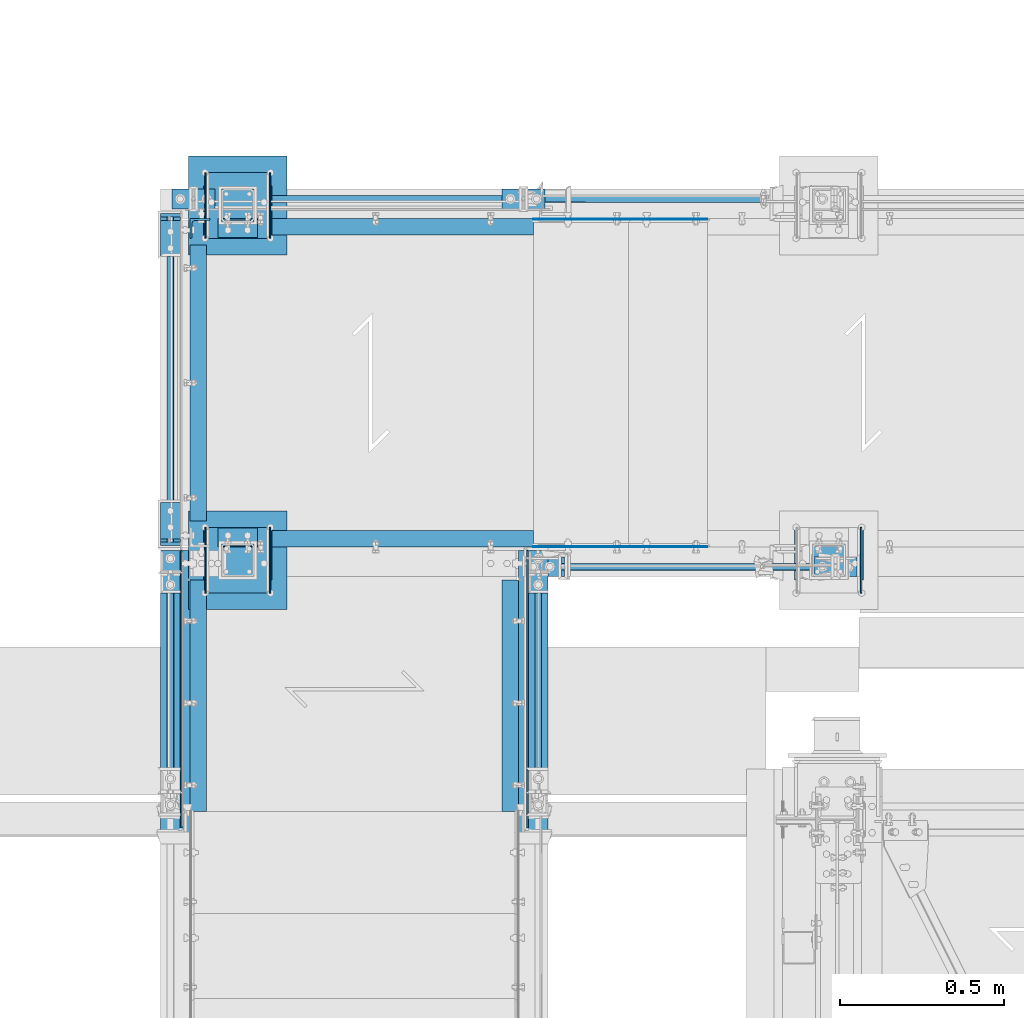
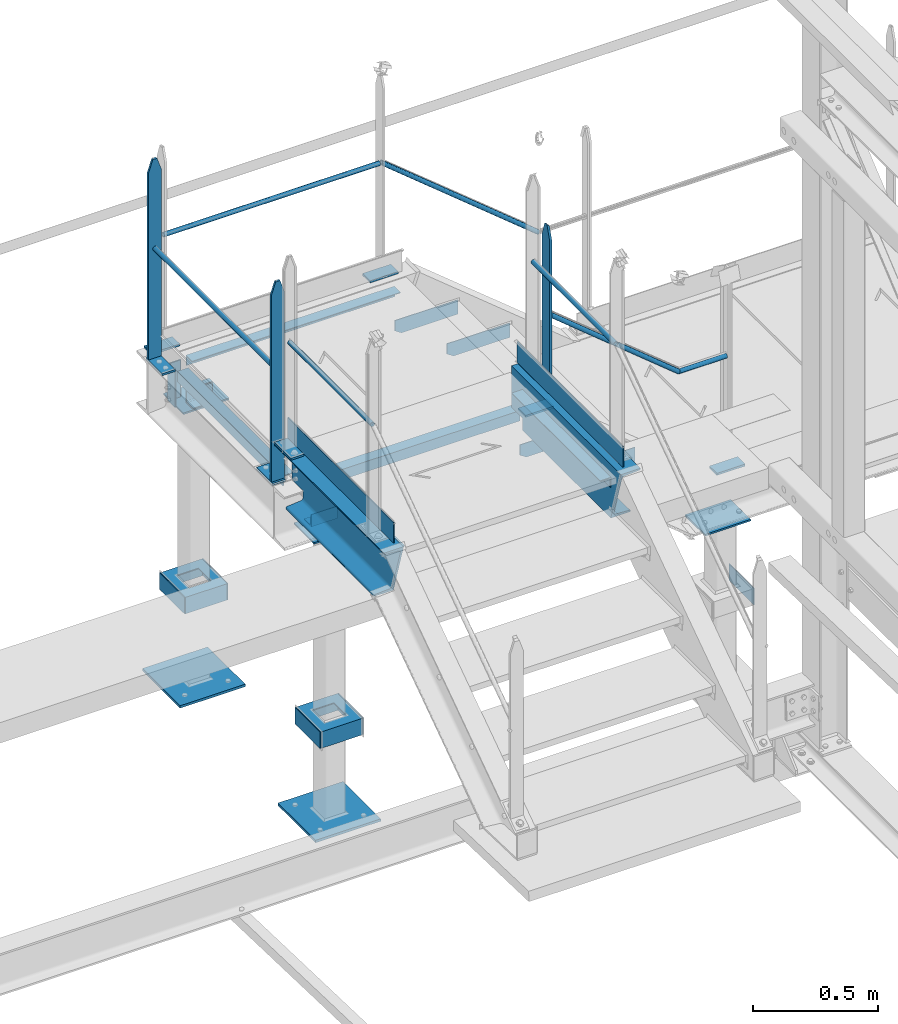
# One storey, part 113 of 496: 44 beams, 2 members, 20 elements without a shape of their own.
"""IFC2X3 building model written with IfcOpenShell, lengths in millimetres."""

from ifc_helpers import new_model, si_unit, frame, origin_with_axes, origin_2d_with_axis, place, context, subcontext, project, spatial, polyline, rectangle, hollow_circle, l_section, u_section, outline, extrude, boolean, clip, halfspace, material, type_object, element, aggregate, save


model = new_model("IFC2X3")

# Units and contexts
model_context = context("Model", 3, precision=1e-05, world=origin_with_axes())
body_context = subcontext(model_context, "Body", "Model", "MODEL_VIEW")
ifc_project = project(units=[si_unit("LENGTHUNIT", "METRE", prefix="MILLI"), si_unit("AREAUNIT", "SQUARE_METRE"), si_unit("VOLUMEUNIT", "CUBIC_METRE"), si_unit("MASSUNIT", "GRAM", prefix="KILO"), si_unit("TIMEUNIT", "SECOND"), si_unit("PLANEANGLEUNIT", "RADIAN"), si_unit("SOLIDANGLEUNIT", "STERADIAN"), si_unit("THERMODYNAMICTEMPERATUREUNIT", "DEGREE_CELSIUS"), si_unit("LUMINOUSINTENSITYUNIT", "LUMEN")], contexts=[model_context])

# Site, building, storey
site_placement = place(None, origin_with_axes())
site = spatial("IfcSite", under=ifc_project, at=site_placement, CompositionType="ELEMENT")
building_placement = place(site_placement, origin_with_axes())
building = spatial("IfcBuilding", under=site, at=building_placement, Name="Undefined", CompositionType="ELEMENT")
storey_placement = place(building_placement, origin_with_axes())
storey = spatial("IfcBuildingStorey", under=building, at=storey_placement, Name="Undefined", CompositionType="ELEMENT", Elevation=0.0)

# Assembly, beams
assembly_1_placement = place(storey_placement, origin_with_axes())
assembly_1 = element("IfcElementAssembly", 1, at=assembly_1_placement, inside=storey, Name="MAIN COURANTE", AssemblyPlace="NOTDEFINED", PredefinedType="NOTDEFINED")
ifc_material_1 = material(Name="Undefined/S235-E24")
beam_type_1 = type_object("IfcBeamType", PredefinedType="NOTDEFINED")
beam_1_placement = place(assembly_1_placement, frame((33460.0061849194, 15970.0000882977, 8705.00015961151), z_axis=(0.0, -1.0, 0.0), x_axis=(-1.0, 0.0, 0.0)))
beam_1 = element("IfcBeam", 2, at=beam_1_placement, type_object=beam_type_1, material=ifc_material_1, context=body_context, shape_type="SweptSolid", body=[
    extrude(rectangle(XDim=10.0, YDim=60.0, at=origin_2d_with_axis()), frame((130.0, 0.0, 0.0), z_axis=(-1.0, 0.0, 0.0), x_axis=(0.0, -1.0, 0.0)), (0.0, 0.0, 1.0), 130.0),
])
beam_2_placement = place(assembly_1_placement, frame((33445.0061849194, 15970.0000882977, 9582.39164232764), z_axis=(0.0, 1.0, 0.0), x_axis=(0.0, 0.0, -1.0)))
beam_2 = element("IfcBeam", 3, at=beam_2_placement, type_object=beam_type_1, material=ifc_material_1, Name="MONTANT", context=body_context, shape_type="Clipping", body=[
    clip(clip(clip(extrude(rectangle(XDim=10.0, YDim=60.0, at=origin_2d_with_axis()), frame((872.391482716137, 0.0, 0.0), z_axis=(-1.0, 0.0, 0.0), x_axis=(0.0, -1.0, 0.0)), (0.0, 0.0, 1.0), 876.53), halfspace(frame((-119.99851575355, -5.0, -30.0), z_axis=(-0.316227766016838, 0.0, 0.948683298050514), x_axis=(0.0, 1.0, 0.0)), False)), halfspace(frame((60.0014842464498, -5.0, -30.0), z_axis=(-0.316227766016838, 0.0, -0.948683298050514), x_axis=(0.0, 1.0, 0.0)), False)), halfspace(frame((7.28321514399249, -8.88829265710956, 0.0), z_axis=(0.773488973625628, 0.633809756693262, 0.0), x_axis=(0.0, 0.0, 1.0)), True)),
])
beam_3_placement = place(assembly_1_placement, frame((34340.0061849194, 15970.0000882977, 8114.9999407569), z_axis=(0.0, -1.0, 0.0), x_axis=(-1.0, 0.0, 0.0)))
beam_3 = element("IfcBeam", 4, at=beam_3_placement, type_object=beam_type_1, material=ifc_material_1, context=body_context, shape_type="SweptSolid", body=[
    extrude(rectangle(XDim=10.0, YDim=60.0, at=origin_2d_with_axis()), frame((130.0, 0.0, 0.0), z_axis=(-1.0, 0.0, 0.0), x_axis=(0.0, -1.0, 0.0)), (0.0, 0.0, 1.0), 130.0),
])

assembly_2_placement = place(storey_placement, origin_with_axes())
assembly_2 = element("IfcElementAssembly", 5, at=assembly_2_placement, inside=storey, Name="MAIN COURANTE", AssemblyPlace="NOTDEFINED", PredefinedType="NOTDEFINED")
beam_4_placement = place(assembly_2_placement, frame((33390.0061849194, 17089.9938659712, 8705.00000001012), z_axis=(0.0, 1.0, 0.0), x_axis=(-1.0, 0.0, 0.0)))
beam_4 = element("IfcBeam", 6, at=beam_4_placement, type_object=beam_type_1, material=ifc_material_1, context=body_context, shape_type="SweptSolid", body=[
    extrude(rectangle(XDim=10.0, YDim=60.0, at=origin_2d_with_axis()), frame((130.0, 0.0, 0.0), z_axis=(-1.0, 0.0, 0.0), x_axis=(0.0, -1.0, 0.0)), (0.0, 0.0, 1.0), 130.0),
])
beam_5_placement = place(assembly_2_placement, frame((32384.9961849194, 17089.9938659712, 8705.00000001012), z_axis=(0.0, 1.0, 0.0), x_axis=(-1.0, 0.0, 0.0)))
beam_5 = element("IfcBeam", 7, at=beam_5_placement, type_object=beam_type_1, material=ifc_material_1, context=body_context, shape_type="SweptSolid", body=[
    extrude(rectangle(XDim=10.0, YDim=60.0, at=origin_2d_with_axis()), frame((130.0, 0.0, 0.0), z_axis=(-1.0, 0.0, 0.0), x_axis=(0.0, -1.0, 0.0)), (0.0, 0.0, 1.0), 130.0),
])

assembly_3_placement = place(storey_placement, origin_with_axes())
assembly_3 = element("IfcElementAssembly", 8, at=assembly_3_placement, inside=storey, Name="MAIN COURANTE", AssemblyPlace="NOTDEFINED", PredefinedType="NOTDEFINED")
beam_6_placement = place(assembly_3_placement, frame((32249.9863365012, 16165.0036560214, 8705.00000001012), z_axis=(-1.0, 0.0, 0.0), x_axis=(0.0, -1.0, 0.0)))
beam_6 = element("IfcBeam", 9, at=beam_6_placement, type_object=beam_type_1, material=ifc_material_1, context=body_context, shape_type="SweptSolid", body=[
    extrude(rectangle(XDim=10.0, YDim=60.0, at=origin_2d_with_axis()), frame((130.0, 0.0, 0.0), z_axis=(-1.0, 0.0, 0.0), x_axis=(0.0, -1.0, 0.0)), (0.0, 0.0, 1.0), 130.0),
])
beam_7_placement = place(assembly_3_placement, frame((32249.9862112009, 16050.0036560214, 9677.59999848012), z_axis=(-0.99999999999782, -2.08799998896818e-06, 0.0), x_axis=(0.0, 0.0, -1.0)))
beam_7 = element("IfcBeam", 10, at=beam_7_placement, type_object=beam_type_1, material=ifc_material_1, Name="MONTANT", context=body_context, shape_type="Clipping", body=[
    clip(clip(extrude(rectangle(XDim=10.0, YDim=60.0, at=origin_2d_with_axis()), frame((967.59999845988, 0.0, 0.0), z_axis=(-1.0, 0.0, 0.0), x_axis=(0.0, -1.0, 0.0)), (0.0, 0.0, 1.0), 967.6), halfspace(frame((-119.999937359999, -4.99999999999636, -30.0), z_axis=(-0.316227766016837, -1.98085072276202e-06, 0.948683298048446), x_axis=(-6.26399999950979e-06, 0.999999999980381, -3.63797880701241e-15)), False)), halfspace(frame((60.0, -5.0, -30.0), z_axis=(-0.316227469016822, 1.98084886235393e-06, -0.948683397048399), x_axis=(6.26399999950979e-06, 0.999999999980381, -3.63797880701241e-15)), False)),
])
beam_8_placement = place(assembly_3_placement, frame((32249.9863365012, 17044.9977309424, 8705.00000001012), z_axis=(-1.0, 0.0, 0.0), x_axis=(0.0, -1.0, 0.0)))
beam_8 = element("IfcBeam", 11, at=beam_8_placement, type_object=beam_type_1, material=ifc_material_1, context=body_context, shape_type="SweptSolid", body=[
    extrude(rectangle(XDim=10.0, YDim=60.0, at=origin_2d_with_axis()), frame((130.0, 0.0, 0.0), z_axis=(-1.0, 0.0, 0.0), x_axis=(0.0, -1.0, 0.0)), (0.0, 0.0, 1.0), 130.0),
])
beam_9_placement = place(assembly_3_placement, frame((32249.9862112009, 17029.9977309424, 9677.59999848012), z_axis=(-0.99999999999782, -2.08799998896818e-06, 0.0), x_axis=(0.0, 0.0, -1.0)))
beam_9 = element("IfcBeam", 12, at=beam_9_placement, type_object=beam_type_1, material=ifc_material_1, Name="MONTANT", context=body_context, shape_type="Clipping", body=[
    clip(clip(extrude(rectangle(XDim=10.0, YDim=60.0, at=origin_2d_with_axis()), frame((967.59999845988, 0.0, 0.0), z_axis=(-1.0, 0.0, 0.0), x_axis=(0.0, -1.0, 0.0)), (0.0, 0.0, 1.0), 967.6), halfspace(frame((-119.999937359999, -4.99999999999636, -30.0), z_axis=(-0.316227766016837, -1.98085072276202e-06, 0.948683298048446), x_axis=(-6.26399999950979e-06, 0.999999999980381, -3.63797880701241e-15)), False)), halfspace(frame((60.0, -5.0, -30.0), z_axis=(-0.316227469016822, 1.98084886235393e-06, -0.948683397048399), x_axis=(6.26399999950979e-06, 0.999999999980381, -3.63797880701241e-15)), False)),
])

# Assembly, beam
assembly_4_placement = place(storey_placement, origin_with_axes())
assembly_4 = element("IfcElementAssembly", 13, at=assembly_4_placement, inside=storey, Name="MAIN COURANTE", AssemblyPlace="NOTDEFINED", PredefinedType="NOTDEFINED")
beam_10_placement = place(assembly_4_placement, frame((32249.9863365012, 16020.003622146, 8915.0), z_axis=(-1.0, 0.0, 0.0), x_axis=(0.0, -1.0, 0.0)))
beam_10 = element("IfcBeam", 14, at=beam_10_placement, type_object=beam_type_1, material=ifc_material_1, context=body_context, shape_type="SweptSolid", body=[
    extrude(rectangle(XDim=10.0, YDim=60.0, at=origin_2d_with_axis()), frame((130.0, 0.0, 0.0), z_axis=(-1.0, 0.0, 0.0), x_axis=(0.0, -1.0, 0.0)), (0.0, 0.0, 1.0), 130.0),
])

assembly_5_placement = place(storey_placement, origin_with_axes())
assembly_5 = element("IfcElementAssembly", 15, at=assembly_5_placement, inside=storey, Name="MAIN COURANTE", AssemblyPlace="NOTDEFINED", PredefinedType="NOTDEFINED")
beam_11_placement = place(assembly_5_placement, frame((33369.9936634988, 16019.9996684868, 8915.0), z_axis=(1.0, 0.0, 0.0), x_axis=(0.0, -1.0, 0.0)))
beam_11 = element("IfcBeam", 16, at=beam_11_placement, type_object=beam_type_1, material=ifc_material_1, context=body_context, shape_type="SweptSolid", body=[
    extrude(rectangle(XDim=10.0, YDim=60.0, at=origin_2d_with_axis()), frame((130.0, 0.0, 0.0), z_axis=(-1.0, 0.0, 0.0), x_axis=(0.0, -1.0, 0.0)), (0.0, 0.0, 1.0), 130.0),
])

# Beam
beam_type_2 = type_object("IfcBeamType", PredefinedType="NOTDEFINED")
beam_12_placement = place(assembly_1_placement, frame((34050.3145397259, 15970.0002031579, 8653.80000001012), z_axis=(0.0, -1.0, 0.0), x_axis=(1.0, 0.0, 0.0)))
beam_12 = element("IfcBeam", 17, at=beam_12_placement, type_object=beam_type_2, material=ifc_material_1, Name="LISSE", context=body_context, shape_type="Clipping", body=[
    clip(extrude(hollow_circle(Radius=10.64999962, WallThickness=2.0, at=origin_2d_with_axis()), frame((219.691645193617, 1.81898940354586e-12, 0.0), z_axis=(-1.0, 0.0, 0.0), x_axis=(0.0, -1.0, 0.0)), (0.0, 0.0, 1.0), 223.54), halfspace(frame((3.80609846942389, 10.6499996200018, 0.000112519470349071), z_axis=(0.941671113820085, -0.336534564935766, -5.79127735785473e-07), x_axis=(-0.336534564313756, -0.941671114042557, 0.0)), True)),
])

beam_13_placement = place(assembly_2_placement, frame((32324.9961849193, 17089.9946261742, 9243.80000001012), z_axis=(0.0, 1.0, 0.0), x_axis=(1.0, 0.0, 0.0)))
beam_13 = element("IfcBeam", 18, at=beam_13_placement, type_object=beam_type_2, material=ifc_material_1, Name="LISSE", context=body_context, shape_type="SweptSolid", body=[
    extrude(hollow_circle(Radius=10.64999962, WallThickness=2.0, at=origin_2d_with_axis()), frame((995.010000000411, 0.0, 5.26753908029906e-20), z_axis=(-1.0, 0.0, 0.0), x_axis=(0.0, -1.0, 0.0)), (0.0, 0.0, 1.0), 995.01),
])

beam_14_placement = place(assembly_5_placement, frame((33369.9936634988, 15290.0038659711, 9438.8), z_axis=(0.999999999998558, -1.69800000185205e-06, 0.0), x_axis=(1.69800000215235e-06, 0.999999999998558, 0.0)))
beam_14 = element("IfcBeam", 19, at=beam_14_placement, type_object=beam_type_2, material=ifc_material_1, Name="LISSE", context=body_context, shape_type="SweptSolid", body=[
    extrude(hollow_circle(Radius=10.64999962, WallThickness=2.0, at=origin_2d_with_axis()), frame((659.995802516527, 1.81898940354586e-12, -1.3975954744526e-19), z_axis=(-1.0, 0.0, 0.0), x_axis=(0.0, -1.0, 0.0)), (0.0, 0.0, 1.0), 660.0),
])

beam_15_placement = place(assembly_3_placement, frame((32249.9863365012, 16055.0036560216, 9243.80000001012), z_axis=(-0.99999999999782, -2.08799998896818e-06, 0.0), x_axis=(-1.15500000027281e-06, 0.999999999999333, 0.0)))
beam_15 = element("IfcBeam", 20, at=beam_15_placement, type_object=beam_type_2, material=ifc_material_1, Name="LISSE", context=body_context, shape_type="SweptSolid", body=[
    extrude(hollow_circle(Radius=10.64999962, WallThickness=2.0, at=origin_2d_with_axis()), frame((969.994074923011, -1.81898940354586e-12, 0.0), z_axis=(-1.0, 0.0, 0.0), x_axis=(0.0, -1.0, 0.0)), (0.0, 0.0, 1.0), 969.99),
])

aggregate(assembly_3, [beam_6, beam_7, beam_15, beam_8, beam_9])

beam_16_placement = place(assembly_4_placement, frame((32249.9863365012, 15290.0038659711, 9438.8), z_axis=(-0.99999999999782, -2.08799998896818e-06, 0.0), x_axis=(-1.15500000027281e-06, 0.999999999999333, 0.0)))
beam_16 = element("IfcBeam", 21, at=beam_16_placement, type_object=beam_type_2, material=ifc_material_1, Name="LISSE", context=body_context, shape_type="SweptSolid", body=[
    extrude(hollow_circle(Radius=10.64999962, WallThickness=2.0, at=origin_2d_with_axis()), frame((659.999756175796, -1.81898940354586e-12, -1.39760384665176e-19), z_axis=(-1.0, 0.0, 0.0), x_axis=(0.0, -1.0, 0.0)), (0.0, 0.0, 1.0), 660.0),
])

# Member
member_type = type_object("IfcMemberType", PredefinedType="NOTDEFINED")
member_1_placement = place(assembly_1_placement, frame((34050.3145397259, 15970.0040747151, 8653.80000001012), z_axis=(0.0, 1.0, 0.0), x_axis=(-0.773488973625643, 0.0, 0.633809756693245)))
member_1 = element("IfcMember", 22, at=member_1_placement, type_object=member_type, material=ifc_material_1, Name="LISSE", context=body_context, shape_type="Clipping", body=[
    clip(clip(extrude(hollow_circle(Radius=10.64999962, WallThickness=2.0, at=origin_2d_with_axis()), frame((794.709650012954, 0.0, 0.0), z_axis=(-1.0, 0.0, 0.0), x_axis=(0.0, -1.0, 0.0)), (0.0, 0.0, 1.0), 813.31), halfspace(frame((787.048146301975, 13.3552820560435, -0.00398641746141948), z_axis=(-0.773488973625642, 0.633809756693246, 0.0), x_axis=(-0.633809756693246, -0.773488973625642, 0.0)), True)), halfspace(frame((3.80609846935113, 10.6499996200037, -0.00398641746141948), z_axis=(-0.941671114042557, 0.336534564313756, 0.0), x_axis=(-0.336534564313756, -0.941671114042557, 0.0)), False)),
])

aggregate(assembly_1, [beam_1, beam_2, beam_3, member_1, beam_12])

member_2_placement = place(assembly_2_placement, frame((34050.3145397259, 17089.9898795537, 8653.80000001012), z_axis=(0.0, -1.0, 0.0), x_axis=(-0.773488973625643, 0.0, 0.633809756693245)))
member_2 = element("IfcMember", 23, at=member_2_placement, type_object=member_type, material=ifc_material_1, Name="LISSE", context=body_context, shape_type="Clipping", body=[
    clip(clip(extrude(hollow_circle(Radius=10.64999962, WallThickness=2.0, at=origin_2d_with_axis()), frame((949.850840245523, 0.0, 0.0), z_axis=(-1.0, 0.0, 0.0), x_axis=(0.0, -1.0, 0.0)), (0.0, 0.0, 1.0), 968.46), halfspace(frame((942.913936082841, -14.2395691075362, -0.00398641746141948), z_axis=(-0.773488973625642, -0.633809756693246, 0.0), x_axis=(0.0, 0.0, -1.0)), True)), halfspace(frame((3.80609846935477, -10.6499996200037, -0.00398641746141948), z_axis=(-0.941671114042507, -0.336534564313897, 0.0), x_axis=(0.0, 0.0, -1.0)), False)),
])

aggregate(assembly_2, [beam_13, beam_4, member_2, beam_5])

# Assembly, beam
assembly_6_placement = place(storey_placement, origin_with_axes())
assembly_6 = element("IfcElementAssembly", 24, at=assembly_6_placement, inside=storey, AssemblyPlace="NOTDEFINED", PredefinedType="NOTDEFINED")
beam_type_3 = type_object("IfcBeamType", PredefinedType="NOTDEFINED")
beam_17_placement = place(assembly_6_placement, frame((32605.0000000001, 15839.9999136253, 7056.0), z_axis=(0.0, 0.0, -1.0), x_axis=(-1.0, 0.0, 0.0)))
beam_17 = element("IfcBeam", 25, at=beam_17_placement, type_object=beam_type_3, material=ifc_material_1, context=body_context, shape_type="SweptSolid", body=[
    extrude(outline(polyline([(0.0, 0.0), (300.0, 0.0), (300.0, 300.0), (0.0, 300.0), (0.0, 0.0)])), frame((0.0, 0.0, -6.0), z_axis=(0.0, 0.0, 1.0), x_axis=(1.0, 0.0, 0.0)), (0.0, 0.0, 1.0), 12.0),
])

assembly_7_placement = place(storey_placement, origin_with_axes())
assembly_7 = element("IfcElementAssembly", 26, at=assembly_7_placement, inside=storey, AssemblyPlace="NOTDEFINED", PredefinedType="NOTDEFINED")
beam_18_placement = place(assembly_7_placement, frame((32605.0000000001, 17219.9996684749, 7056.0), z_axis=(0.0, 0.0, 1.0), x_axis=(-1.0, 0.0, 0.0)))
beam_18 = element("IfcBeam", 27, at=beam_18_placement, type_object=beam_type_3, material=ifc_material_1, context=body_context, shape_type="SweptSolid", body=[
    extrude(outline(polyline([(0.0, 0.0), (300.0, 0.0), (300.0, 300.0), (0.0, 300.0), (0.0, 0.0)])), frame((0.0, 0.0, -6.0), z_axis=(0.0, 0.0, 1.0), x_axis=(1.0, 0.0, 0.0)), (0.0, 0.0, 1.0), 12.0),
])

# Beam
beam_type_4 = type_object("IfcBeamType", PredefinedType="NOTDEFINED")
beam_19_placement = place(assembly_4_placement, frame((32282.4987221813, 16020.0036847861, 8970.0), z_axis=(0.0, 0.0, -1.0), x_axis=(0.0, -1.0, 0.0)))
beam_19 = element("IfcBeam", 28, at=beam_19_placement, type_object=beam_type_4, material=ifc_material_1, context=body_context, shape_type="SweptSolid", body=[
    extrude(rectangle(XDim=5.0, YDim=100.0, at=origin_2d_with_axis()), frame((845.00389373597, 0.0, 0.0), z_axis=(-1.0, 0.0, 0.0), x_axis=(0.0, -1.0, 0.0)), (0.0, 0.0, 1.0), 845.0),
])

aggregate(assembly_4, [beam_16, beam_19, beam_10])

beam_20_placement = place(assembly_5_placement, frame((33337.4812778187, 16019.9997311268, 8970.0), z_axis=(0.0, 0.0, -1.0), x_axis=(0.0, -1.0, 0.0)))
beam_20 = element("IfcBeam", 29, at=beam_20_placement, type_object=beam_type_4, material=ifc_material_1, context=body_context, shape_type="SweptSolid", body=[
    extrude(rectangle(XDim=5.0, YDim=100.0, at=origin_2d_with_axis()), frame((844.999940076701, 0.0, 0.0), z_axis=(-1.0, 0.0, 0.0), x_axis=(0.0, -1.0, 0.0)), (0.0, 0.0, 1.0), 845.0),
])

aggregate(assembly_5, [beam_14, beam_20, beam_11])

beam_type_5 = type_object("IfcBeamType", PredefinedType="NOTDEFINED")
beam_21_placement = place(assembly_6_placement, frame((32560.0000000001, 15930.0004325462, 8436.00011661134), z_axis=(0.0, 0.0, -1.0), x_axis=(-1.0, 0.0, 0.0)))
beam_21 = element("IfcBeam", 30, at=beam_21_placement, type_object=beam_type_5, material=ifc_material_1, context=body_context, shape_type="SweptSolid", body=[
    extrude(outline(polyline([(0.0, 0.0), (210.0, 0.0), (210.0, 159.999481201172), (0.0, 159.999481201172), (0.0, 0.0)])), frame((0.0, 0.0, -4.0), z_axis=(0.0, 0.0, 1.0), x_axis=(1.0, 0.0, 0.0)), (0.0, 0.0, 1.0), 8.0),
])

# Assembly, beam
assembly_8_placement = place(storey_placement, origin_with_axes())
assembly_8 = element("IfcElementAssembly", 31, at=assembly_8_placement, inside=storey, AssemblyPlace="NOTDEFINED", PredefinedType="NOTDEFINED")
beam_22_placement = place(assembly_8_placement, frame((34360.0000000001, 15930.0004325462, 7846.00001160755), z_axis=(0.0, 0.0, -1.0), x_axis=(-1.0, 0.0, 0.0)))
beam_22 = element("IfcBeam", 32, at=beam_22_placement, type_object=beam_type_5, material=ifc_material_1, context=body_context, shape_type="SweptSolid", body=[
    extrude(outline(polyline([(0.0, 0.0), (210.0, 0.0), (210.0, 159.999481201172), (0.0, 159.999481201172), (0.0, 0.0)])), frame((0.0, 0.0, -4.0), z_axis=(0.0, 0.0, 1.0), x_axis=(1.0, 0.0, 0.0)), (0.0, 0.0, 1.0), 8.0),
])

# Beam
beam_23_placement = place(assembly_7_placement, frame((32560.0000000001, 17129.9991495539, 8436.00011661134), z_axis=(0.0, 0.0, 1.0), x_axis=(-1.0, 0.0, 0.0)))
beam_23 = element("IfcBeam", 33, at=beam_23_placement, type_object=beam_type_5, material=ifc_material_1, context=body_context, shape_type="SweptSolid", body=[
    extrude(outline(polyline([(0.0, 0.0), (210.0, 0.0), (210.0, 159.999481201172), (0.0, 159.999481201172), (0.0, 0.0)])), frame((0.0, 0.0, -4.0), z_axis=(0.0, 0.0, 1.0), x_axis=(1.0, 0.0, 0.0)), (0.0, 0.0, 1.0), 8.0),
])

beam_type_6 = type_object("IfcBeamType", PredefinedType="NOTDEFINED")
beam_24_placement = place(assembly_6_placement, frame((32553.0000000001, 16089.9999136253, 7500.0), z_axis=(0.0, 0.0, 1.0), x_axis=(0.0, -1.0, 0.0)))
beam_24 = element("IfcBeam", 34, at=beam_24_placement, type_object=beam_type_6, material=ifc_material_1, Name="BORD", context=body_context, shape_type="SweptSolid", body=[
    extrude(rectangle(XDim=4.0, YDim=80.0, at=origin_2d_with_axis()), frame((200.0, 0.0, 0.0), z_axis=(-1.0, 0.0, 0.0), x_axis=(0.0, -1.0, 0.0)), (0.0, 0.0, 1.0), 200.0),
])

beam_25_placement = place(assembly_8_placement, frame((34353.0000000001, 16089.9999136253, 7500.0), z_axis=(0.0, 0.0, 1.0), x_axis=(0.0, -1.0, 0.0)))
beam_25 = element("IfcBeam", 35, at=beam_25_placement, type_object=beam_type_6, material=ifc_material_1, Name="BORD", context=body_context, shape_type="SweptSolid", body=[
    extrude(rectangle(XDim=4.0, YDim=80.0, at=origin_2d_with_axis()), frame((200.0, 0.0, 0.0), z_axis=(-1.0, 0.0, 0.0), x_axis=(0.0, -1.0, 0.0)), (0.0, 0.0, 1.0), 200.0),
])

aggregate(assembly_8, [beam_22, beam_25])

beam_26_placement = place(assembly_6_placement, frame((32357.0000000001, 16089.9999136253, 7500.0), z_axis=(0.0, 0.0, 1.0), x_axis=(0.0, -1.0, 0.0)))
beam_26 = element("IfcBeam", 36, at=beam_26_placement, type_object=beam_type_6, material=ifc_material_1, Name="BORD", context=body_context, shape_type="SweptSolid", body=[
    extrude(rectangle(XDim=4.0, YDim=80.0, at=origin_2d_with_axis()), frame((200.0, 0.0, 0.0), z_axis=(-1.0, 0.0, 0.0), x_axis=(0.0, -1.0, 0.0)), (0.0, 0.0, 1.0), 200.0),
])

beam_27_placement = place(assembly_7_placement, frame((32553.0000000001, 16969.9996684749, 7500.0), z_axis=(0.0, 0.0, 1.0), x_axis=(0.0, 1.0, 0.0)))
beam_27 = element("IfcBeam", 37, at=beam_27_placement, type_object=beam_type_6, material=ifc_material_1, Name="BORD", context=body_context, shape_type="SweptSolid", body=[
    extrude(rectangle(XDim=4.0, YDim=80.0, at=origin_2d_with_axis()), frame((200.0, 0.0, 0.0), z_axis=(-1.0, 0.0, 0.0), x_axis=(0.0, -1.0, 0.0)), (0.0, 0.0, 1.0), 200.0),
])

beam_28_placement = place(assembly_7_placement, frame((32357.0000000001, 16969.9996684749, 7500.0), z_axis=(0.0, 0.0, 1.0), x_axis=(0.0, 1.0, 0.0)))
beam_28 = element("IfcBeam", 38, at=beam_28_placement, type_object=beam_type_6, material=ifc_material_1, Name="BORD", context=body_context, shape_type="SweptSolid", body=[
    extrude(rectangle(XDim=4.0, YDim=80.0, at=origin_2d_with_axis()), frame((200.0, 0.0, 0.0), z_axis=(-1.0, 0.0, 0.0), x_axis=(0.0, -1.0, 0.0)), (0.0, 0.0, 1.0), 200.0),
])

beam_type_7 = type_object("IfcBeamType", PredefinedType="NOTDEFINED")
beam_29_placement = place(assembly_6_placement, frame((32551.0000000001, 15989.9999136253, 7500.0), z_axis=(0.0, 1.0, 0.0), x_axis=(-1.0, 0.0, 0.0)))
beam_29 = element("IfcBeam", 39, at=beam_29_placement, type_object=beam_type_7, material=ifc_material_1, context=body_context, shape_type="CSG", body=[
    boolean("DIFFERENCE", extrude(u_section(Depth=200.0, FlangeWidth=80.0, WebThickness=4.0, FlangeThickness=4.0, at=origin_2d_with_axis()), frame((192.0, 0.0, 0.0), z_axis=(-1.0, 0.0, 0.0), x_axis=(0.0, -1.0, 0.0)), (0.0, 0.0, 1.0), 192.0), extrude(outline(polyline([(0.0, 0.0), (101.0, 0.0), (101.0, 101.0), (0.0, 101.0), (0.0, 0.0)])), frame((146.5, -42.5, 50.5), z_axis=(0.0, 1.0, 0.0), x_axis=(0.0, 0.0, -1.0)), (0.0, 0.0, 1.0), 85.0)),
])

aggregate(assembly_6, [beam_21, beam_24, beam_26, beam_29, beam_17])

beam_30_placement = place(assembly_7_placement, frame((32359.0000000001, 17069.9996684749, 7500.0), z_axis=(0.0, -1.0, 0.0), x_axis=(1.0, 0.0, 0.0)))
beam_30 = element("IfcBeam", 40, at=beam_30_placement, type_object=beam_type_7, material=ifc_material_1, context=body_context, shape_type="CSG", body=[
    boolean("DIFFERENCE", extrude(u_section(Depth=200.0, FlangeWidth=80.0, WebThickness=4.0, FlangeThickness=4.0, at=origin_2d_with_axis()), frame((192.0, 0.0, 0.0), z_axis=(-1.0, 0.0, 0.0), x_axis=(0.0, -1.0, 0.0)), (0.0, 0.0, 1.0), 192.0), extrude(outline(polyline([(0.0, 0.0), (101.0, 0.0), (101.0, 101.0), (0.0, 101.0), (0.0, 0.0)])), frame((45.5, -42.5, -50.5), z_axis=(0.0, 1.0, 0.0), x_axis=(0.0, 0.0, 1.0)), (0.0, 0.0, 1.0), 85.0)),
])

aggregate(assembly_7, [beam_23, beam_27, beam_28, beam_30, beam_18])

# Assembly, beam
assembly_9_placement = place(storey_placement, origin_with_axes())
assembly_9 = element("IfcElementAssembly", 41, at=assembly_9_placement, inside=storey, Name="SUPPORT", AssemblyPlace="NOTDEFINED", PredefinedType="NOTDEFINED")
beam_type_8 = type_object("IfcBeamType", PredefinedType="NOTDEFINED")
beam_31_placement = place(assembly_9_placement, frame((33284.9814327271, 15930.0058468547, 8825.0), z_axis=(-1.0, 0.0, 0.0), x_axis=(0.0, -1.0, 0.0)))
beam_31 = element("IfcBeam", 42, at=beam_31_placement, type_object=beam_type_8, material=ifc_material_1, Name="SUPPORT", context=body_context, shape_type="SweptSolid", body=[
    extrude(l_section(Depth=50.0, Width=50.0, Thickness=5.0, FilletRadius=7.0, EdgeRadius=3.5, at=origin_2d_with_axis()), frame((704.999999999984, 0.0, 0.0), z_axis=(-1.0, 0.0, 0.0), x_axis=(0.0, -1.0, 0.0)), (0.0, 0.0, 1.0), 705.0),
])
aggregate(assembly_9, [beam_31])

assembly_10_placement = place(storey_placement, origin_with_axes())
assembly_10 = element("IfcElementAssembly", 43, at=assembly_10_placement, inside=storey, Name="SUPPORT", AssemblyPlace="NOTDEFINED", PredefinedType="NOTDEFINED")
beam_32_placement = place(assembly_10_placement, frame((32335.0061849613, 15225.0058468548, 8825.0), z_axis=(1.0, 0.0, 0.0), x_axis=(0.0, 1.0, 0.0)))
beam_32 = element("IfcBeam", 44, at=beam_32_placement, type_object=beam_type_8, material=ifc_material_1, Name="SUPPORT", context=body_context, shape_type="SweptSolid", body=[
    extrude(l_section(Depth=50.0, Width=50.0, Thickness=5.0, FilletRadius=7.0, EdgeRadius=3.5, at=origin_2d_with_axis()), frame((704.999999999984, 0.0, 0.0), z_axis=(-1.0, 0.0, 0.0), x_axis=(0.0, -1.0, 0.0)), (0.0, 0.0, 1.0), 705.0),
])
aggregate(assembly_10, [beam_32])

assembly_11_placement = place(storey_placement, origin_with_axes())
assembly_11 = element("IfcElementAssembly", 45, at=assembly_11_placement, inside=storey, Name="SUPPORT", AssemblyPlace="NOTDEFINED", PredefinedType="NOTDEFINED")
beam_33_placement = place(assembly_11_placement, frame((33354.9999902605, 16055.006211263, 8645.0), z_axis=(0.0, 1.0, 0.0), x_axis=(-1.0, 0.0, 0.0)))
beam_33 = element("IfcBeam", 46, at=beam_33_placement, type_object=beam_type_8, material=ifc_material_1, Name="SUPPORT", context=body_context, shape_type="SweptSolid", body=[
    extrude(l_section(Depth=50.0, Width=50.0, Thickness=5.0, FilletRadius=7.0, EdgeRadius=3.5, at=origin_2d_with_axis()), frame((959.999229763376, 0.0, -1.98523187731526e-22), z_axis=(-1.0, 0.0, 0.0), x_axis=(0.0, -1.0, 0.0)), (0.0, 0.0, 1.0), 960.0),
])
aggregate(assembly_11, [beam_33])

assembly_12_placement = place(storey_placement, origin_with_axes())
assembly_12 = element("IfcElementAssembly", 47, at=assembly_12_placement, inside=storey, Name="SUPPORT", AssemblyPlace="NOTDEFINED", PredefinedType="NOTDEFINED")
beam_34_placement = place(assembly_12_placement, frame((32335.0061849613, 16109.9933715032, 8645.0), z_axis=(1.0, 0.0, 0.0), x_axis=(0.0, 1.0, 0.0)))
beam_34 = element("IfcBeam", 48, at=beam_34_placement, type_object=beam_type_8, material=ifc_material_1, Name="SUPPORT", context=body_context, shape_type="SweptSolid", body=[
    extrude(l_section(Depth=50.0, Width=50.0, Thickness=5.0, FilletRadius=7.0, EdgeRadius=3.5, at=origin_2d_with_axis()), frame((839.999999999982, 0.0, 0.0), z_axis=(-1.0, 0.0, 0.0), x_axis=(0.0, -1.0, 0.0)), (0.0, 0.0, 1.0), 840.0),
])
aggregate(assembly_12, [beam_34])

assembly_13_placement = place(storey_placement, origin_with_axes())
assembly_13 = element("IfcElementAssembly", 49, at=assembly_13_placement, inside=storey, Name="SUPPORT", AssemblyPlace="NOTDEFINED", PredefinedType="NOTDEFINED")
beam_35_placement = place(assembly_13_placement, frame((32395.0007604971, 17004.9933717972, 8645.0), z_axis=(0.0, -1.0, 0.0), x_axis=(1.0, 0.0, 0.0)))
beam_35 = element("IfcBeam", 50, at=beam_35_placement, type_object=beam_type_8, material=ifc_material_1, Name="SUPPORT", context=body_context, shape_type="SweptSolid", body=[
    extrude(l_section(Depth=50.0, Width=50.0, Thickness=5.0, FilletRadius=7.0, EdgeRadius=3.5, at=origin_2d_with_axis()), frame((959.999229763376, 0.0, -1.98523187731526e-22), z_axis=(-1.0, 0.0, 0.0), x_axis=(0.0, -1.0, 0.0)), (0.0, 0.0, 1.0), 960.0),
])
aggregate(assembly_13, [beam_35])

assembly_14_placement = place(storey_placement, origin_with_axes())
assembly_14 = element("IfcElementAssembly", 51, at=assembly_14_placement, inside=storey, AssemblyPlace="NOTDEFINED", PredefinedType="NOTDEFINED")
ifc_material_2 = material(Name="Undefined/S275-E28")
beam_type_9 = type_object("IfcBeamType", Name="UPN260", PredefinedType="NOTDEFINED")
beam_36_placement = place(assembly_14_placement, frame((33355.0056513211, 16019.9995858327, 8780.0), z_axis=(0.0, 0.0, -1.0), x_axis=(-1.69800000215235e-06, -0.999999999998558, 0.0)))
beam_36 = element("IfcBeam", 52, at=beam_36_placement, type_object=beam_type_9, material=ifc_material_2, ObjectType="UPN260", context=body_context, shape_type="CSG", body=[
    boolean("DIFFERENCE", boolean("DIFFERENCE", extrude(u_section(Depth=260.0, FlangeWidth=90.0, WebThickness=10.0, FlangeThickness=14.0, FilletRadius=14.0, EdgeRadius=7.0, FlangeSlope=0.0798299857122373, at=origin_2d_with_axis()), frame((874.295008193708, 1.8513916939001e-19, 0.0), z_axis=(-1.0, 0.0, 0.0), x_axis=(0.0, -1.0, 0.0)), (0.0, 0.0, 1.0), 874.3), extrude(outline(polyline([(0.0, 0.0), (90.0001678466797, 0.0), (90.0001678466797, 100.0), (0.0, 100.0), (0.0, 0.0)])), frame((89.9958784172661, -47.9984209859495, 160.0), z_axis=(1.69800000215235e-06, 0.999999999998558, 0.0), x_axis=(0.0, 0.0, -1.0)), (0.0, 0.0, 1.0), 96.0)), halfspace(frame((792.671784930781, 545.010387020859, 130.000000010119), z_axis=(0.954513538946677, -1.75248685872726e-06, 0.29816757698385), x_axis=(1.69800000215235e-06, 0.999999999998558, 0.0)), False)),
])
aggregate(assembly_14, [beam_36])

assembly_15_placement = place(storey_placement, origin_with_axes())
assembly_15 = element("IfcElementAssembly", 53, at=assembly_15_placement, inside=storey, AssemblyPlace="NOTDEFINED", PredefinedType="NOTDEFINED")
beam_37_placement = place(assembly_15_placement, frame((32265.0039852279, 15146.1108193981, 8779.99999998988), z_axis=(0.0, 0.0, -1.0), x_axis=(-1.15500000027281e-06, 0.999999999999333, 0.0)))
beam_37 = element("IfcBeam", 54, at=beam_37_placement, type_object=beam_type_9, material=ifc_material_2, ObjectType="UPN260", context=body_context, shape_type="CSG", body=[
    boolean("DIFFERENCE", boolean("DIFFERENCE", extrude(u_section(Depth=260.0, FlangeWidth=90.0, WebThickness=10.0, FlangeThickness=14.0, FilletRadius=14.0, EdgeRadius=7.0, FlangeSlope=0.0798299857122373, at=origin_2d_with_axis()), frame((873.892720094798, 0.0, 1.81898940354586e-12), z_axis=(-1.0, 0.0, 0.0), x_axis=(0.0, -1.0, 0.0)), (0.0, 0.0, 1.0), 874.3), extrude(outline(polyline([(0.0, 0.0), (90.0001678466797, 0.0), (90.0001678466797, 100.0), (0.0, 100.0), (0.0, 0.0)])), frame((783.892696460834, 48.0006366731568, 159.999999989883), z_axis=(1.15500000027281e-06, -0.999999999999333, 0.0), x_axis=(0.0, 0.0, -1.0)), (0.0, 0.0, 1.0), 96.0)), halfspace(frame((-0.000917900219064904, 544.989823727126, -130.000000000049), z_axis=(0.954513538946678, 1.75248685699101e-06, -0.298167576983845), x_axis=(1.15500000027281e-06, -0.999999999999333, 0.0)), True)),
])
aggregate(assembly_15, [beam_37])

# Assembly, beams
assembly_16_placement = place(storey_placement, origin_with_axes())
assembly_16 = element("IfcElementAssembly", 55, at=assembly_16_placement, inside=storey, Name="MARCHE", AssemblyPlace="NOTDEFINED", PredefinedType="NOTDEFINED")
beam_type_10 = type_object("IfcBeamType", PredefinedType="NOTDEFINED")
beam_38_placement = place(assembly_16_placement, frame((33644.9999902344, 17028.4999136338, 8503.3299407569), z_axis=(0.0, 1.0, 0.0), x_axis=(0.0, 0.0, -1.0)))
beam_38 = element("IfcBeam", 56, at=beam_38_placement, type_object=beam_type_10, material=ifc_material_1, Name="PLAT MARCHE", context=body_context, shape_type="SweptSolid", body=[
    extrude(outline(polyline([(0.0, 0.0), (70.0, 0.0), (70.0, 260.0), (50.0, 290.0), (0.0, 290.0), (0.0, 0.0)])), frame((0.0, 0.0, -1.5), z_axis=(0.0, 0.0, 1.0), x_axis=(1.0, 0.0, 0.0)), (0.0, 0.0, 1.0), 3.0),
])
beam_39_placement = place(assembly_16_placement, frame((33644.9999902344, 16031.4996684663, 8503.3299407569), z_axis=(0.0, 1.0, 0.0), x_axis=(0.0, 0.0, -1.0)))
beam_39 = element("IfcBeam", 57, at=beam_39_placement, type_object=beam_type_10, material=ifc_material_1, Name="PLAT MARCHE", context=body_context, shape_type="SweptSolid", body=[
    extrude(outline(polyline([(0.0, 0.0), (70.0, 0.0), (70.0, 260.0), (50.0, 290.0), (0.0, 290.0), (0.0, 0.0)])), frame((0.0, 0.0, -1.5), z_axis=(0.0, 0.0, 1.0), x_axis=(1.0, 0.0, 0.0)), (0.0, 0.0, 1.0), 3.0),
])
aggregate(assembly_16, [beam_38, beam_39])

assembly_17_placement = place(storey_placement, origin_with_axes())
assembly_17 = element("IfcElementAssembly", 58, at=assembly_17_placement, inside=storey, Name="MARCHE", AssemblyPlace="NOTDEFINED", PredefinedType="NOTDEFINED")
beam_40_placement = place(assembly_17_placement, frame((33884.9999902344, 17028.4999136338, 8306.6699407569), z_axis=(0.0, 1.0, 0.0), x_axis=(0.0, 0.0, -1.0)))
beam_40 = element("IfcBeam", 59, at=beam_40_placement, type_object=beam_type_10, material=ifc_material_1, Name="PLAT MARCHE", context=body_context, shape_type="SweptSolid", body=[
    extrude(outline(polyline([(0.0, 0.0), (70.0, 0.0), (70.0, 260.0), (50.0, 290.0), (0.0, 290.0), (0.0, 0.0)])), frame((0.0, 0.0, -1.5), z_axis=(0.0, 0.0, 1.0), x_axis=(1.0, 0.0, 0.0)), (0.0, 0.0, 1.0), 3.0),
])
beam_41_placement = place(assembly_17_placement, frame((33884.9999902344, 16031.4996684663, 8306.6699407569), z_axis=(0.0, 1.0, 0.0), x_axis=(0.0, 0.0, -1.0)))
beam_41 = element("IfcBeam", 60, at=beam_41_placement, type_object=beam_type_10, material=ifc_material_1, Name="PLAT MARCHE", context=body_context, shape_type="SweptSolid", body=[
    extrude(outline(polyline([(0.0, 0.0), (70.0, 0.0), (70.0, 260.0), (50.0, 290.0), (0.0, 290.0), (0.0, 0.0)])), frame((0.0, 0.0, -1.5), z_axis=(0.0, 0.0, 1.0), x_axis=(1.0, 0.0, 0.0)), (0.0, 0.0, 1.0), 3.0),
])
aggregate(assembly_17, [beam_40, beam_41])

# Assembly, beam
assembly_18_placement = place(storey_placement, origin_with_axes())
assembly_18 = element("IfcElementAssembly", 61, at=assembly_18_placement, inside=storey, AssemblyPlace="NOTDEFINED", PredefinedType="NOTDEFINED")
beam_type_11 = type_object("IfcBeamType", PredefinedType="NOTDEFINED")
beam_42_placement = place(assembly_18_placement, frame((32515.0000000001, 16059.9999136126, 8470.00004576069), z_axis=(0.0, 0.0, 1.0), x_axis=(-1.0, 0.0, 0.0)))
beam_42 = element("IfcBeam", 62, at=beam_42_placement, type_object=beam_type_11, material=ifc_material_1, context=body_context, shape_type="SweptSolid", body=[
    extrude(l_section(Depth=60.0, Width=60.0, Thickness=6.0, FilletRadius=8.0, EdgeRadius=4.0, at=origin_2d_with_axis()), frame((120.0, 0.0, 0.0), z_axis=(-1.0, 0.0, 0.0), x_axis=(0.0, -1.0, 0.0)), (0.0, 0.0, 1.0), 120.0),
])
aggregate(assembly_18, [beam_42])

assembly_19_placement = place(storey_placement, origin_with_axes())
assembly_19 = element("IfcElementAssembly", 63, at=assembly_19_placement, inside=storey, AssemblyPlace="NOTDEFINED", PredefinedType="NOTDEFINED")
beam_43_placement = place(assembly_19_placement, frame((32395.0000000001, 16999.9996684876, 8470.00004576069), z_axis=(0.0, 0.0, 1.0), x_axis=(1.0, 0.0, 0.0)))
beam_43 = element("IfcBeam", 64, at=beam_43_placement, type_object=beam_type_11, material=ifc_material_1, context=body_context, shape_type="SweptSolid", body=[
    extrude(l_section(Depth=60.0, Width=60.0, Thickness=6.0, FilletRadius=8.0, EdgeRadius=4.0, at=origin_2d_with_axis()), frame((120.0, 0.0, 0.0), z_axis=(-1.0, 0.0, 0.0), x_axis=(0.0, -1.0, 0.0)), (0.0, 0.0, 1.0), 120.0),
])
aggregate(assembly_19, [beam_43])

assembly_20_placement = place(storey_placement, origin_with_axes())
assembly_20 = element("IfcElementAssembly", 65, at=assembly_20_placement, inside=storey, AssemblyPlace="NOTDEFINED", PredefinedType="NOTDEFINED")
beam_44_placement = place(assembly_20_placement, frame((32340.0061851836, 16999.9933718197, 8660.0), z_axis=(1.0, 0.0, 0.0), x_axis=(0.0, 0.0, -1.0)))
beam_44 = element("IfcBeam", 66, at=beam_44_placement, type_object=beam_type_11, material=ifc_material_1, context=body_context, shape_type="SweptSolid", body=[
    extrude(l_section(Depth=60.0, Width=60.0, Thickness=6.0, FilletRadius=8.0, EdgeRadius=4.0, at=origin_2d_with_axis()), frame((180.0, 0.0, 0.0), z_axis=(-1.0, 0.0, 0.0), x_axis=(0.0, -1.0, 0.0)), (0.0, 0.0, 1.0), 180.0),
])
aggregate(assembly_20, [beam_44])

save(model, "model.ifc")
